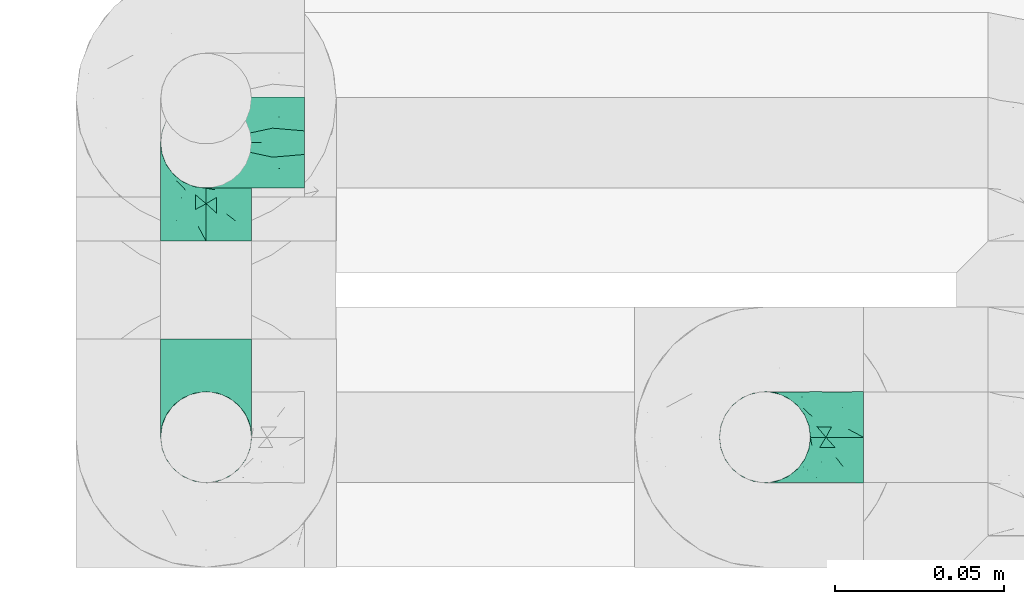
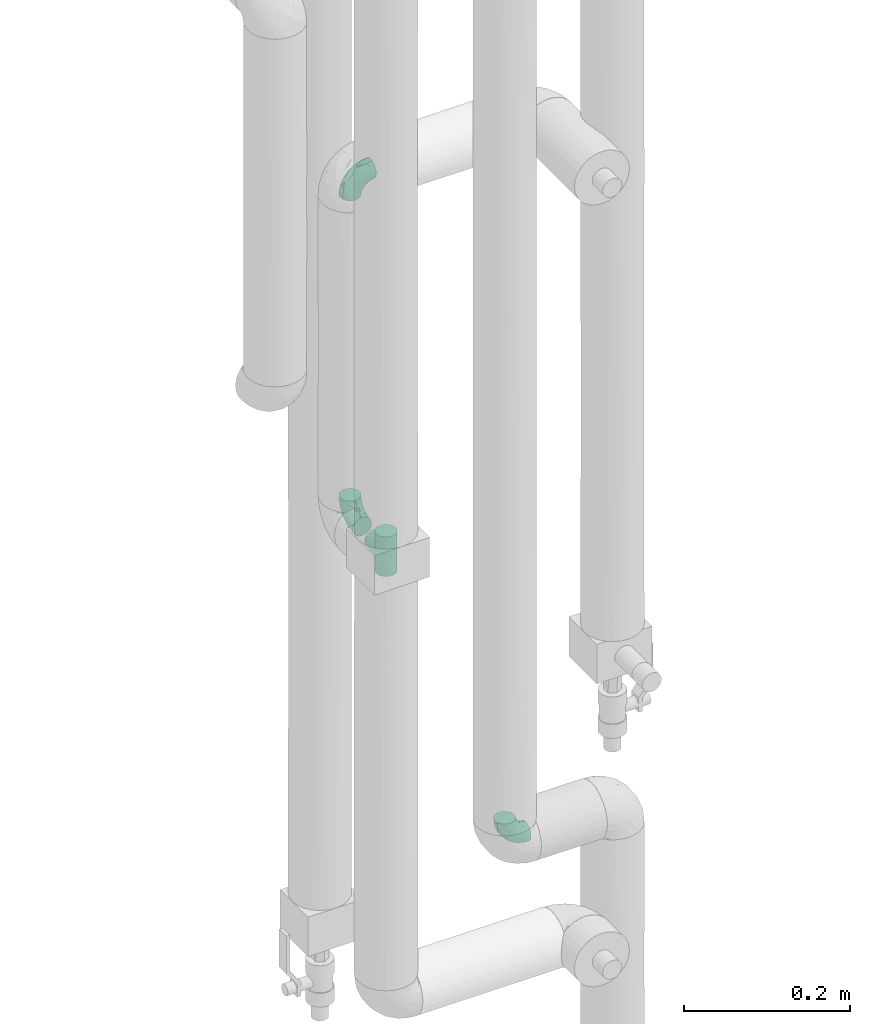
# One storey, part 758 of 827: 4 flow fittings.
"""IFC2X3 building model written with IfcOpenShell, lengths in millimetres."""

from ifc_helpers import new_model, entity, si_unit, converted_unit, derived_unit, direction, frame, origin, place, context, subcontext, project, spatial, faceted_brep, source, transform, mapped, material, type_object, type_shapes, element, save


model = new_model("IFC2X3")

# Units and contexts
model_context = context("Model", 3, precision=0.01, world=origin(), true_north=direction((6.12303176911189e-17, 1.0)))
body_context = subcontext(model_context, "Body", "Model", "MODEL_VIEW")
ifc_project = project(units=[si_unit("LENGTHUNIT", "METRE", prefix="MILLI"), si_unit("AREAUNIT", "SQUARE_METRE"), si_unit("VOLUMEUNIT", "CUBIC_METRE"), converted_unit("PLANEANGLEUNIT", "DEGREE", entity("IfcRatioMeasure", 0.0174532925199433), si_unit("PLANEANGLEUNIT", "RADIAN"), dimensions=[0, 0, 0, 0, 0, 0, 0]), si_unit("MASSUNIT", "GRAM", prefix="KILO"), derived_unit("MASSDENSITYUNIT", [(si_unit("MASSUNIT", "GRAM", prefix="KILO"), 1), (si_unit("LENGTHUNIT", "METRE"), -3)]), derived_unit("MOMENTOFINERTIAUNIT", [(si_unit("LENGTHUNIT", "METRE"), 4)]), si_unit("TIMEUNIT", "SECOND"), si_unit("FREQUENCYUNIT", "HERTZ"), si_unit("THERMODYNAMICTEMPERATUREUNIT", "DEGREE_CELSIUS"), derived_unit("THERMALTRANSMITTANCEUNIT", [(si_unit("MASSUNIT", "GRAM", prefix="KILO"), 1), (si_unit("THERMODYNAMICTEMPERATUREUNIT", "KELVIN"), -1), (si_unit("TIMEUNIT", "SECOND"), -3)]), derived_unit("VOLUMETRICFLOWRATEUNIT", [(si_unit("LENGTHUNIT", "METRE"), 3), (si_unit("TIMEUNIT", "SECOND"), -1)]), derived_unit("MASSFLOWRATEUNIT", [(si_unit("MASSUNIT", "GRAM", prefix="KILO"), 1), (si_unit("TIMEUNIT", "SECOND"), -1)]), derived_unit("ROTATIONALFREQUENCYUNIT", [(si_unit("TIMEUNIT", "SECOND"), -1)]), si_unit("ELECTRICCURRENTUNIT", "AMPERE"), si_unit("ELECTRICVOLTAGEUNIT", "VOLT"), si_unit("POWERUNIT", "WATT"), si_unit("FORCEUNIT", "NEWTON", prefix="KILO"), si_unit("ILLUMINANCEUNIT", "LUX"), si_unit("LUMINOUSFLUXUNIT", "LUMEN"), si_unit("LUMINOUSINTENSITYUNIT", "CANDELA"), derived_unit("USERDEFINED", [(si_unit("MASSUNIT", "GRAM", prefix="KILO"), -1), (si_unit("LENGTHUNIT", "METRE"), -2), (si_unit("TIMEUNIT", "SECOND"), 3), (si_unit("LUMINOUSFLUXUNIT", "LUMEN"), 1)]), derived_unit("LINEARVELOCITYUNIT", [(si_unit("LENGTHUNIT", "METRE"), 1), (si_unit("TIMEUNIT", "SECOND"), -1)]), si_unit("PRESSUREUNIT", "PASCAL"), derived_unit("USERDEFINED", [(si_unit("LENGTHUNIT", "METRE"), -2), (si_unit("MASSUNIT", "GRAM", prefix="KILO"), 1), (si_unit("TIMEUNIT", "SECOND"), -2)]), derived_unit("LINEARFORCEUNIT", [(si_unit("MASSUNIT", "GRAM", prefix="KILO"), 1), (si_unit("LENGTHUNIT", "METRE"), 1), (si_unit("TIMEUNIT", "SECOND"), -2), (si_unit("LENGTHUNIT", "METRE"), -1)]), derived_unit("PLANARFORCEUNIT", [(si_unit("MASSUNIT", "GRAM", prefix="KILO"), 1), (si_unit("LENGTHUNIT", "METRE"), 1), (si_unit("TIMEUNIT", "SECOND"), -2), (si_unit("LENGTHUNIT", "METRE"), -2)])], contexts=[model_context])

# Site, building, storey
site_placement = place(None, origin())
site = spatial("IfcSite", under=ifc_project, at=site_placement, CompositionType="ELEMENT")
building_placement = place(site_placement, origin())
building = spatial("IfcBuilding", under=site, at=building_placement, CompositionType="ELEMENT")
storey_placement = place(building_placement, frame((0.0, 0.0, 28200.0)))
storey = spatial("IfcBuildingStorey", under=building, at=storey_placement, Name="08", CompositionType="ELEMENT", Elevation=28200.0)

# Flow fittings
ifc_material = material()
pipe_fitting_type_1 = type_object("IfcPipeFittingType", Name="ADSK_1", PredefinedType="NOTDEFINED", material=ifc_material)
shared_shape_1 = source(origin(), body_context, "Body", "Brep", [
    faceted_brep([(-29.1, 0.0, -13.45), (-29.1, -3.48, -12.99), (-29.1, -6.73, -11.65), (-29.1, -9.51, -9.51), (-29.1, -11.65, -6.73), (-29.1, -12.99, -3.48), (-29.1, -13.45, 0.0), (-29.1, -12.99, 3.48), (-29.1, -11.65, 6.72), (-29.1, -9.51, 9.51), (-29.1, -6.73, 11.65), (-29.1, -3.48, 12.99), (-29.1, 0.0, 13.45), (-29.1, 3.48, 12.99), (-29.1, 6.72, 11.65), (-29.1, 9.51, 9.51), (-29.1, 11.65, 6.72), (-29.1, 12.99, 3.48), (-29.1, 13.45, 0.0), (-29.1, 12.99, -3.48), (-29.1, 11.65, -6.73), (-29.1, 9.51, -9.51), (-29.1, 6.72, -11.65), (-29.1, 3.48, -12.99), (-3.48, 29.1, -12.99), (-6.72, 29.1, -11.65), (-9.51, 29.1, -9.51), (-11.65, 29.1, -6.73), (-12.99, 29.1, -3.48), (-13.45, 29.1, 0.0), (-12.99, 29.1, 3.48), (-11.65, 29.1, 6.72), (-9.51, 29.1, 9.51), (-6.72, 29.1, 11.65), (-3.48, 29.1, 12.99), (0.0, 29.1, 13.45), (3.48, 29.1, 12.99), (6.73, 29.1, 11.65), (9.51, 29.1, 9.51), (11.65, 29.1, 6.72), (12.99, 29.1, 3.48), (13.45, 29.1, 0.0), (12.99, 29.1, -3.48), (11.65, 29.1, -6.73), (9.51, 29.1, -9.51), (6.73, 29.1, -11.65), (3.48, 29.1, -12.99), (0.0, 29.1, -13.45), (-19.62, -11.66, 4.28), (-21.41, -10.36, 7.6), (-16.26, -10.01, 0.0), (-12.48, -9.76, 2.75), (-10.66, 15.6, 11.91), (-15.27, 9.55, 12.42), (-10.71, 10.71, 13.09), (-0.04, 0.04, 0.0), (0.49, -0.45, 4.38), (-3.67, -4.15, 4.26), (-22.68, -11.73, 0.0), (-21.45, -4.97, 12.13), (-11.59, -2.84, 11.28), (-14.77, 0.17, 13.07), (-19.08, -7.58, 10.06), (-22.36, -1.69, 13.23), (-20.49, 2.21, 13.42), (-7.82, -7.75, 0.0), (-5.53, -2.55, 8.58), (-1.33, -0.87, 6.53), (-1.15, 1.15, 8.49), (-22.46, 5.38, 12.69), (-14.04, 21.05, 6.04), (-3.19, 3.19, 11.14), (-5.08, 25.05, 12.59), (-1.97, 21.79, 13.41), (-22.68, 11.31, 8.78), (-18.16, 12.64, 9.68), (-20.46, 14.33, 6.11), (-4.13, 10.11, 13.26), (-7.66, 3.08, 12.63), (-2.02, 8.24, 12.45), (-24.91, 8.22, 10.95), (-5.08, 14.28, 13.42), (-8.96, 6.48, 13.4), (-19.7, 16.14, 3.1), (-18.03, 18.03, 0.0), (-23.05, 15.96, 0.0), (-25.26, 12.69, 5.56), (4.97, 21.45, 12.13), (7.58, 19.08, 10.06), (1.69, 22.36, 13.23), (10.36, 21.41, 7.6), (8.11, 12.69, 6.86), (11.66, 19.62, 4.28), (-6.03, 19.65, 12.79), (9.76, 12.48, 2.75), (10.01, 16.26, 0.0), (-14.58, 16.06, 9.44), (-11.19, 23.14, 8.74), (-16.29, 16.8, 7.24), (-11.99, -5.68, 9.36), (-15.42, 20.78, 3.08), (5.79, 12.02, 9.27), (2.84, 11.59, 11.28), (2.55, 5.53, 8.58), (-15.74, 23.57, 0.0), (-15.96, 23.05, 0.0), (-24.62, 13.88, 2.39), (-8.61, 22.49, 11.12), (-14.98, 12.8, 11.14), (11.73, 22.68, 0.0), (-12.69, -8.11, 6.86), (7.75, 7.82, 0.0), (-15.98, 6.12, 13.19), (-14.48, 3.64, 13.45), (-19.6, 9.46, 11.31), (-8.3, 15.02, 12.85), (-0.17, 14.77, 13.07), (-6.9, -5.2, 6.52), (7.5, 8.93, 4.46), (5.22, 6.95, 6.56), (-8.85, -7.47, 4.42), (3.86, 3.93, 0.0), (4.18, 3.75, 4.31), (-23.57, 15.74, 0.0), (-3.93, -3.86, 0.0), (-21.79, 1.97, -13.41), (-11.31, 22.68, -8.78), (-14.33, 20.46, -6.11), (-12.69, 25.26, -5.56), (4.97, 21.45, -12.13), (2.84, 11.59, -11.28), (-0.17, 14.77, -13.07), (-25.05, 5.08, -12.59), (-16.8, 16.29, -7.24), (-20.78, 15.42, -3.08), (-16.14, 19.7, -3.1), (-12.02, -5.79, -9.27), (-11.59, -2.84, -11.28), (-5.53, -2.55, -8.58), (-23.14, 11.19, -8.74), (-22.49, 8.61, -11.12), (-1.33, -0.87, -6.53), (-3.67, -4.15, -4.26), (-6.9, -5.2, -6.52), (-19.65, 6.03, -12.79), (-15.6, 10.66, -11.91), (-14.28, 5.08, -13.42), (-10.71, 10.71, -13.09), (-6.48, 8.96, -13.4), (-19.62, -11.66, -4.28), (-21.41, -10.36, -7.6), (-12.48, -9.76, -2.75), (11.66, 19.62, -4.28), (-12.69, -8.11, -6.86), (-22.36, -1.69, -13.23), (-16.06, 14.58, -9.44), (5.68, 11.99, -9.36), (7.58, 19.08, -10.06), (-19.08, -7.58, -10.06), (-21.45, -4.97, -12.13), (-9.55, 15.27, -12.42), (-12.8, 14.98, -11.14), (-8.22, 24.91, -10.95), (10.36, 21.41, -7.6), (-5.38, 22.46, -12.69), (1.69, 22.36, -13.23), (-2.21, 20.49, -13.42), (-12.64, 18.16, -9.68), (-21.05, 14.04, -6.04), (9.76, 12.48, -2.75), (-10.11, 4.13, -13.26), (-3.08, 7.66, -12.63), (-8.24, 2.02, -12.45), (-13.88, 24.62, -2.39), (8.11, 12.69, -6.86), (-6.12, 15.98, -13.19), (-3.64, 14.48, -13.45), (-9.46, 19.6, -11.31), (-15.02, 8.3, -12.85), (-14.77, 0.17, -13.07), (-3.19, 3.19, -11.14), (5.22, 6.95, -6.56), (2.55, 5.53, -8.58), (0.49, -0.45, -4.38), (4.18, 3.75, -4.31), (-8.85, -7.47, -4.42), (-1.15, 1.15, -8.49), (7.5, 8.93, -4.46)], [[[0, 1, 2, 3, 4, 5, 6, 7, 8, 9, 10, 11, 12, 13, 14, 15, 16, 17, 18, 19, 20, 21, 22, 23]], [[24, 25, 26, 27, 28, 29, 30, 31, 32, 33, 34, 35, 36, 37, 38, 39, 40, 41, 42, 43, 44, 45, 46, 47]], [[48, 49, 8]], [[48, 50, 51]], [[52, 53, 54]], [[55, 56, 57]], [[49, 9, 8]], [[58, 48, 7]], [[59, 60, 61]], [[62, 10, 9]], [[62, 59, 10]], [[12, 63, 64]], [[51, 50, 65]], [[66, 67, 68]], [[12, 11, 63]], [[69, 14, 13]], [[31, 30, 70]], [[66, 71, 60]], [[34, 72, 73]], [[74, 75, 76]], [[77, 78, 79]], [[14, 80, 15]], [[16, 15, 74]], [[81, 54, 82]], [[83, 84, 85]], [[74, 76, 86]], [[37, 87, 88]], [[88, 38, 37]], [[36, 35, 89]], [[90, 91, 92]], [[93, 81, 73]], [[35, 34, 73]], [[10, 59, 11]], [[92, 94, 95]], [[96, 97, 98]], [[90, 92, 39]], [[99, 60, 62]], [[40, 39, 92]], [[87, 37, 36]], [[100, 84, 83]], [[50, 48, 58]], [[100, 83, 98]], [[101, 102, 103]], [[104, 105, 84, 100, 29]], [[48, 8, 7]], [[86, 17, 16]], [[106, 18, 17]], [[32, 97, 107]], [[53, 52, 108]], [[52, 93, 107]], [[97, 96, 107]], [[72, 107, 93]], [[72, 34, 33]], [[92, 109, 40]], [[33, 32, 107]], [[69, 13, 64]], [[88, 87, 102]], [[12, 64, 13]], [[49, 110, 62]], [[39, 38, 90]], [[95, 94, 111]], [[112, 113, 82]], [[53, 69, 112]], [[80, 74, 15]], [[114, 108, 75]], [[32, 31, 97]], [[115, 52, 54]], [[93, 115, 81]], [[89, 73, 116]], [[106, 76, 83]], [[106, 83, 85]], [[83, 76, 98]], [[100, 30, 29]], [[60, 59, 62]], [[63, 59, 61]], [[110, 117, 99]], [[60, 71, 78]], [[89, 87, 36]], [[116, 79, 102]], [[116, 102, 87]], [[102, 71, 103]], [[110, 49, 48]], [[62, 9, 49]], [[38, 88, 90]], [[91, 90, 88]], [[112, 69, 64]], [[80, 69, 114]], [[111, 94, 118]], [[119, 101, 103]], [[117, 66, 99]], [[117, 120, 57]], [[119, 91, 101]], [[66, 68, 71]], [[66, 117, 67]], [[121, 111, 122, 55]], [[56, 55, 122]], [[31, 70, 97]], [[97, 70, 98]], [[107, 96, 52]], [[53, 108, 114]], [[112, 82, 54]], [[116, 73, 81]], [[78, 82, 61]], [[81, 82, 77]], [[73, 89, 35]], [[87, 89, 116]], [[59, 63, 11]], [[64, 63, 61]], [[112, 64, 113]], [[53, 112, 54]], [[7, 6, 58]], [[109, 92, 95]], [[109, 41, 40]], [[69, 53, 114]], [[52, 96, 108]], [[75, 108, 96]], [[75, 96, 98]], [[114, 75, 74]], [[64, 61, 113]], [[61, 82, 113]], [[91, 88, 101]], [[110, 48, 51]], [[92, 91, 94]], [[91, 119, 118]], [[106, 85, 123, 18]], [[106, 17, 86]], [[60, 78, 61]], [[79, 78, 71]], [[102, 79, 71]], [[77, 79, 116]], [[81, 77, 116]], [[78, 77, 82]], [[69, 80, 14]], [[74, 80, 114]], [[74, 86, 16]], [[106, 86, 76]], [[107, 72, 33]], [[73, 72, 93]], [[98, 70, 100]], [[75, 98, 76]], [[30, 100, 70]], [[110, 99, 62]], [[66, 60, 99]], [[120, 110, 51]], [[67, 117, 57]], [[57, 56, 67]], [[67, 122, 119]], [[110, 120, 117]], [[65, 120, 51]], [[57, 65, 124, 55]], [[122, 67, 56]], [[67, 103, 68]], [[71, 68, 103]], [[65, 57, 120]], [[102, 101, 88]], [[67, 119, 103]], [[118, 119, 122]], [[118, 122, 111]], [[91, 118, 94]], [[81, 115, 54]], [[93, 52, 115]], [[23, 125, 0]], [[126, 127, 128]], [[129, 130, 131]], [[23, 22, 132]], [[133, 134, 135]], [[136, 137, 138]], [[21, 139, 140]], [[141, 142, 143]], [[144, 140, 145]], [[143, 136, 138]], [[146, 147, 148]], [[144, 132, 140]], [[5, 4, 149]], [[4, 3, 150]], [[45, 129, 46]], [[151, 50, 149]], [[152, 43, 42]], [[42, 41, 109]], [[150, 149, 4]], [[153, 149, 150]], [[154, 1, 0]], [[139, 155, 140]], [[156, 130, 157]], [[149, 58, 5]], [[18, 123, 85, 84, 134]], [[158, 159, 137]], [[84, 105, 135]], [[160, 145, 161]], [[143, 153, 136]], [[27, 26, 126]], [[25, 162, 26]], [[152, 163, 43]], [[25, 24, 164]], [[47, 165, 166]], [[158, 3, 2]], [[167, 127, 126]], [[20, 19, 168]], [[47, 46, 165]], [[44, 157, 45]], [[23, 132, 125]], [[44, 43, 163]], [[158, 2, 159]], [[47, 166, 24]], [[129, 45, 157]], [[164, 24, 166]], [[134, 84, 135]], [[95, 169, 152]], [[22, 21, 140]], [[144, 146, 125]], [[109, 152, 42]], [[95, 152, 109]], [[170, 171, 172]], [[155, 139, 133]], [[28, 27, 128]], [[159, 2, 1]], [[173, 29, 28]], [[50, 151, 65]], [[169, 95, 111]], [[163, 174, 157]], [[175, 176, 148]], [[160, 164, 175]], [[162, 126, 26]], [[177, 161, 167]], [[21, 20, 139]], [[144, 145, 178]], [[144, 178, 146]], [[154, 125, 179]], [[173, 127, 135]], [[173, 135, 105]], [[135, 127, 133]], [[134, 19, 18]], [[154, 159, 1]], [[179, 172, 137]], [[179, 137, 159]], [[137, 180, 138]], [[130, 129, 157]], [[165, 129, 131]], [[174, 181, 156]], [[130, 180, 171]], [[3, 158, 150]], [[153, 150, 158]], [[174, 163, 152]], [[157, 44, 163]], [[175, 164, 166]], [[162, 164, 177]], [[130, 182, 180]], [[181, 141, 182]], [[55, 183, 184]], [[65, 151, 185]], [[183, 55, 142]], [[156, 181, 182]], [[180, 182, 186]], [[181, 187, 184]], [[65, 142, 55, 124]], [[20, 168, 139]], [[139, 168, 133]], [[140, 155, 145]], [[160, 161, 177]], [[175, 148, 147]], [[179, 125, 146]], [[171, 148, 131]], [[146, 148, 170]], [[125, 154, 0]], [[159, 154, 179]], [[129, 165, 46]], [[166, 165, 131]], [[175, 166, 176]], [[160, 175, 147]], [[58, 149, 50]], [[58, 6, 5]], [[145, 160, 147]], [[164, 160, 177]], [[145, 155, 161]], [[167, 161, 155]], [[167, 155, 133]], [[177, 167, 126]], [[166, 131, 176]], [[131, 148, 176]], [[149, 153, 151]], [[153, 143, 185]], [[145, 147, 178]], [[174, 152, 169]], [[173, 105, 104, 29]], [[173, 28, 128]], [[130, 171, 131]], [[172, 171, 180]], [[137, 172, 180]], [[170, 172, 179]], [[146, 170, 179]], [[171, 170, 148]], [[164, 162, 25]], [[126, 162, 177]], [[126, 128, 27]], [[173, 128, 127]], [[140, 132, 22]], [[125, 132, 144]], [[133, 168, 134]], [[167, 133, 127]], [[19, 134, 168]], [[153, 158, 136]], [[137, 136, 158]], [[141, 143, 138]], [[185, 143, 142]], [[186, 141, 138]], [[183, 142, 141]], [[185, 142, 65]], [[153, 185, 151]], [[180, 186, 138]], [[182, 141, 186]], [[141, 184, 183]], [[184, 111, 121, 55]], [[174, 156, 157]], [[182, 130, 156]], [[187, 174, 169]], [[141, 181, 184]], [[174, 187, 181]], [[111, 187, 169]], [[111, 184, 187]], [[146, 178, 147]]]),
])
type_shapes(pipe_fitting_type_1, [shared_shape_1])
flow_fitting_1_placement = place(storey_placement, frame((34690.42, 18334.91, 1230.0), z_axis=(0.0, 1.0, 0.0), x_axis=(-1.0, 0.0, 0.0)))
element("IfcFlowFitting", 1, at=flow_fitting_1_placement, inside=storey, type_object=pipe_fitting_type_1, material=ifc_material, Name="ADSK_1", ObjectType="ADSK_1", context=body_context, shape_type="MappedRepresentation", body=[
    mapped(shared_shape_1, transform((0.0, 0.0, 0.0), scale=1.0)),
])
pipe_fitting_type_2 = type_object("IfcPipeFittingType", Name="ADSK_1", PredefinedType="NOTDEFINED", material=ifc_material)
shared_shape_2 = source(origin(), body_context, "Body", "Brep", [
    faceted_brep([(-29.1, -3.48, -12.99), (-29.1, -6.72, -11.65), (-29.1, -9.51, -9.51), (-29.1, -11.65, -6.73), (-29.1, -12.99, -3.48), (-29.1, -13.45, 0.0), (-29.1, -12.99, 3.48), (-29.1, -11.65, 6.72), (-29.1, -9.51, 9.51), (-29.1, -6.72, 11.65), (-29.1, -3.48, 12.99), (-29.1, 0.0, 13.45), (-29.1, 3.48, 12.99), (-29.1, 6.73, 11.65), (-29.1, 9.51, 9.51), (-29.1, 11.65, 6.72), (-29.1, 12.99, 3.48), (-29.1, 13.45, 0.0), (-29.1, 12.99, -3.48), (-29.1, 11.65, -6.73), (-29.1, 9.51, -9.51), (-29.1, 6.73, -11.65), (-29.1, 3.48, -12.99), (-29.1, 0.0, -13.45), (0.0, -29.1, -13.45), (3.48, -29.1, -12.99), (6.73, -29.1, -11.65), (9.51, -29.1, -9.51), (11.65, -29.1, -6.73), (12.99, -29.1, -3.48), (13.45, -29.1, 0.0), (12.99, -29.1, 3.48), (11.65, -29.1, 6.72), (9.51, -29.1, 9.51), (6.73, -29.1, 11.65), (3.48, -29.1, 12.99), (0.0, -29.1, 13.45), (-3.48, -29.1, 12.99), (-6.72, -29.1, 11.65), (-9.51, -29.1, 9.51), (-11.65, -29.1, 6.72), (-12.99, -29.1, 3.48), (-13.45, -29.1, 0.0), (-12.99, -29.1, -3.48), (-11.65, -29.1, -6.73), (-9.51, -29.1, -9.51), (-6.72, -29.1, -11.65), (-3.48, -29.1, -12.99), (-21.41, 10.36, 7.6), (-19.62, 11.66, 4.28), (-12.48, 9.76, 2.75), (-16.26, 10.01, 0.0), (-10.71, -10.71, 13.09), (-15.27, -9.55, 12.42), (-10.66, -15.6, 11.91), (-3.67, 4.15, 4.26), (0.49, 0.45, 4.38), (-0.04, -0.04, 0.0), (-22.68, 11.73, 0.0), (-14.77, -0.17, 13.07), (-11.59, 2.84, 11.28), (-21.45, 4.97, 12.13), (-19.08, 7.58, 10.06), (-20.49, -2.21, 13.42), (-22.36, 1.69, 13.23), (-7.82, 7.75, 0.0), (-1.15, -1.15, 8.49), (-1.33, 0.87, 6.53), (-5.53, 2.55, 8.58), (-22.46, -5.38, 12.69), (-14.04, -21.05, 6.04), (-3.19, -3.19, 11.14), (-1.97, -21.79, 13.41), (-5.08, -25.05, 12.59), (-20.46, -14.33, 6.11), (-18.16, -12.64, 9.68), (-22.68, -11.31, 8.78), (-2.02, -8.24, 12.45), (-7.66, -3.08, 12.63), (-4.13, -10.11, 13.26), (-24.91, -8.22, 10.95), (-8.96, -6.48, 13.4), (-5.08, -14.28, 13.42), (-23.05, -15.96, 0.0), (-18.03, -18.03, 0.0), (-19.7, -16.14, 3.1), (-25.26, -12.69, 5.56), (7.58, -19.08, 10.06), (4.97, -21.45, 12.13), (1.69, -22.36, 13.23), (11.66, -19.62, 4.28), (8.11, -12.69, 6.86), (10.36, -21.41, 7.6), (-6.03, -19.65, 12.79), (10.01, -16.26, 0.0), (9.76, -12.48, 2.75), (-16.29, -16.8, 7.24), (-11.19, -23.14, 8.74), (-14.58, -16.06, 9.44), (-11.99, 5.68, 9.36), (-15.42, -20.78, 3.08), (2.55, -5.53, 8.58), (2.84, -11.59, 11.28), (5.79, -12.02, 9.27), (-15.96, -23.05, 0.0), (-15.74, -23.57, 0.0), (-24.62, -13.88, 2.39), (-8.61, -22.49, 11.12), (-14.98, -12.8, 11.14), (11.73, -22.68, 0.0), (-12.69, 8.11, 6.86), (7.75, -7.82, 0.0), (-14.48, -3.64, 13.45), (-15.98, -6.12, 13.19), (-19.6, -9.46, 11.31), (-8.3, -15.02, 12.85), (-0.17, -14.77, 13.07), (-6.9, 5.2, 6.52), (7.5, -8.93, 4.46), (5.22, -6.95, 6.56), (-8.85, 7.47, 4.42), (4.18, -3.75, 4.31), (3.86, -3.93, 0.0), (-23.57, -15.74, 0.0), (-3.93, 3.86, 0.0), (-21.79, -1.97, -13.41), (-12.69, -25.26, -5.56), (-14.33, -20.46, -6.11), (-11.31, -22.68, -8.78), (-0.17, -14.77, -13.07), (2.84, -11.59, -11.28), (4.97, -21.45, -12.13), (-25.05, -5.08, -12.59), (-16.14, -19.7, -3.1), (-20.78, -15.42, -3.08), (-16.8, -16.29, -7.24), (-5.53, 2.55, -8.58), (-11.59, 2.84, -11.28), (-12.02, 5.79, -9.27), (-22.49, -8.61, -11.12), (-23.14, -11.19, -8.74), (-6.9, 5.2, -6.52), (-3.67, 4.15, -4.26), (-1.33, 0.87, -6.53), (-15.6, -10.66, -11.91), (-19.65, -6.03, -12.79), (-6.48, -8.96, -13.4), (-10.71, -10.71, -13.09), (-14.28, -5.08, -13.42), (-19.62, 11.66, -4.28), (-21.41, 10.36, -7.6), (-12.48, 9.76, -2.75), (11.66, -19.62, -4.28), (-12.69, 8.11, -6.86), (-22.36, 1.69, -13.23), (-16.06, -14.58, -9.44), (7.58, -19.08, -10.06), (5.68, -11.99, -9.36), (-21.45, 4.97, -12.13), (-19.08, 7.58, -10.06), (-12.8, -14.98, -11.14), (-9.55, -15.27, -12.42), (-8.22, -24.91, -10.95), (10.36, -21.41, -7.6), (-5.38, -22.46, -12.69), (-2.21, -20.49, -13.42), (1.69, -22.36, -13.23), (-12.64, -18.16, -9.68), (-21.05, -14.04, -6.04), (9.76, -12.48, -2.75), (-8.24, -2.02, -12.45), (-3.08, -7.66, -12.63), (-10.11, -4.13, -13.26), (-13.88, -24.62, -2.39), (8.11, -12.69, -6.86), (-3.64, -14.48, -13.45), (-6.12, -15.98, -13.19), (-9.46, -19.6, -11.31), (-15.02, -8.3, -12.85), (-14.77, -0.17, -13.07), (-3.19, -3.19, -11.14), (5.22, -6.95, -6.56), (2.55, -5.53, -8.58), (4.18, -3.75, -4.31), (0.49, 0.45, -4.38), (-8.85, 7.47, -4.42), (-1.15, -1.15, -8.49), (7.5, -8.93, -4.46)], [[[0, 1, 2, 3, 4, 5, 6, 7, 8, 9, 10, 11, 12, 13, 14, 15, 16, 17, 18, 19, 20, 21, 22, 23]], [[24, 25, 26, 27, 28, 29, 30, 31, 32, 33, 34, 35, 36, 37, 38, 39, 40, 41, 42, 43, 44, 45, 46, 47]], [[15, 48, 49]], [[50, 51, 49]], [[52, 53, 54]], [[55, 56, 57]], [[15, 14, 48]], [[16, 49, 58]], [[59, 60, 61]], [[14, 13, 62]], [[13, 61, 62]], [[63, 64, 11]], [[65, 51, 50]], [[66, 67, 68]], [[64, 12, 11]], [[10, 9, 69]], [[70, 41, 40]], [[60, 71, 68]], [[72, 73, 37]], [[74, 75, 76]], [[77, 78, 79]], [[8, 80, 9]], [[76, 8, 7]], [[81, 52, 82]], [[83, 84, 85]], [[86, 74, 76]], [[87, 88, 34]], [[34, 33, 87]], [[89, 36, 35]], [[90, 91, 92]], [[72, 82, 93]], [[72, 37, 36]], [[12, 61, 13]], [[94, 95, 90]], [[96, 97, 98]], [[32, 90, 92]], [[62, 60, 99]], [[90, 32, 31]], [[35, 34, 88]], [[85, 84, 100]], [[58, 49, 51]], [[96, 85, 100]], [[101, 102, 103]], [[42, 100, 84, 104, 105]], [[16, 15, 49]], [[7, 6, 86]], [[6, 5, 106]], [[107, 97, 39]], [[108, 54, 53]], [[107, 93, 54]], [[107, 98, 97]], [[93, 107, 73]], [[38, 37, 73]], [[31, 109, 90]], [[107, 39, 38]], [[63, 10, 69]], [[102, 88, 87]], [[10, 63, 11]], [[62, 110, 48]], [[92, 33, 32]], [[111, 95, 94]], [[81, 112, 113]], [[113, 69, 53]], [[8, 76, 80]], [[75, 108, 114]], [[97, 40, 39]], [[52, 54, 115]], [[82, 115, 93]], [[116, 72, 89]], [[85, 74, 106]], [[83, 85, 106]], [[96, 74, 85]], [[42, 41, 100]], [[62, 61, 60]], [[59, 61, 64]], [[99, 117, 110]], [[78, 71, 60]], [[35, 88, 89]], [[102, 77, 116]], [[88, 102, 116]], [[101, 71, 102]], [[49, 48, 110]], [[48, 14, 62]], [[92, 87, 33]], [[87, 92, 91]], [[63, 69, 113]], [[114, 69, 80]], [[118, 95, 111]], [[101, 103, 119]], [[99, 68, 117]], [[55, 120, 117]], [[103, 91, 119]], [[71, 66, 68]], [[67, 117, 68]], [[121, 111, 122, 57]], [[121, 57, 56]], [[97, 70, 40]], [[96, 70, 97]], [[54, 98, 107]], [[114, 108, 53]], [[52, 81, 113]], [[82, 72, 116]], [[59, 81, 78]], [[79, 81, 82]], [[36, 89, 72]], [[116, 89, 88]], [[12, 64, 61]], [[59, 64, 63]], [[112, 63, 113]], [[52, 113, 53]], [[58, 17, 16]], [[94, 90, 109]], [[31, 30, 109]], [[114, 53, 69]], [[108, 98, 54]], [[98, 108, 75]], [[96, 98, 75]], [[76, 75, 114]], [[112, 59, 63]], [[112, 81, 59]], [[103, 87, 91]], [[50, 49, 110]], [[95, 91, 90]], [[118, 119, 91]], [[106, 5, 123, 83]], [[86, 6, 106]], [[59, 78, 60]], [[71, 78, 77]], [[71, 77, 102]], [[116, 77, 79]], [[116, 79, 82]], [[81, 79, 78]], [[9, 80, 69]], [[114, 80, 76]], [[7, 86, 76]], [[74, 86, 106]], [[38, 73, 107]], [[93, 73, 72]], [[100, 70, 96]], [[74, 96, 75]], [[70, 100, 41]], [[62, 99, 110]], [[99, 60, 68]], [[50, 110, 120]], [[55, 117, 67]], [[67, 56, 55]], [[119, 121, 67]], [[117, 120, 110]], [[50, 120, 65]], [[124, 65, 55, 57]], [[56, 67, 121]], [[66, 101, 67]], [[101, 66, 71]], [[120, 55, 65]], [[87, 103, 102]], [[101, 119, 67]], [[121, 119, 118]], [[111, 121, 118]], [[95, 118, 91]], [[52, 115, 82]], [[115, 54, 93]], [[23, 125, 0]], [[126, 127, 128]], [[129, 130, 131]], [[132, 1, 0]], [[133, 134, 135]], [[136, 137, 138]], [[139, 140, 2]], [[141, 142, 143]], [[144, 139, 145]], [[136, 138, 141]], [[146, 147, 148]], [[139, 132, 145]], [[149, 19, 18]], [[150, 20, 19]], [[25, 131, 26]], [[149, 51, 151]], [[29, 28, 152]], [[109, 30, 29]], [[19, 149, 150]], [[150, 149, 153]], [[23, 22, 154]], [[139, 155, 140]], [[156, 130, 157]], [[18, 58, 149]], [[134, 84, 83, 123, 5]], [[137, 158, 159]], [[133, 104, 84]], [[160, 144, 161]], [[138, 153, 141]], [[128, 45, 44]], [[45, 162, 46]], [[28, 163, 152]], [[164, 47, 46]], [[165, 166, 24]], [[21, 20, 159]], [[128, 127, 167]], [[168, 4, 3]], [[166, 25, 24]], [[26, 156, 27]], [[125, 132, 0]], [[163, 28, 27]], [[158, 21, 159]], [[47, 165, 24]], [[156, 26, 131]], [[165, 47, 164]], [[133, 84, 134]], [[152, 169, 94]], [[139, 2, 1]], [[125, 148, 145]], [[29, 152, 109]], [[109, 152, 94]], [[170, 171, 172]], [[135, 140, 155]], [[126, 44, 43]], [[22, 21, 158]], [[43, 42, 173]], [[65, 151, 51]], [[111, 94, 169]], [[156, 174, 163]], [[146, 175, 176]], [[176, 164, 161]], [[45, 128, 162]], [[167, 160, 177]], [[140, 3, 2]], [[178, 144, 145]], [[148, 178, 145]], [[179, 125, 154]], [[133, 127, 173]], [[104, 133, 173]], [[135, 127, 133]], [[5, 4, 134]], [[22, 158, 154]], [[137, 170, 179]], [[158, 137, 179]], [[136, 180, 137]], [[156, 131, 130]], [[129, 131, 166]], [[157, 181, 174]], [[171, 180, 130]], [[150, 159, 20]], [[159, 150, 153]], [[152, 163, 174]], [[163, 27, 156]], [[165, 164, 176]], [[177, 164, 162]], [[180, 182, 130]], [[182, 143, 181]], [[183, 184, 57]], [[185, 151, 65]], [[142, 57, 184]], [[182, 181, 157]], [[186, 182, 180]], [[183, 187, 181]], [[124, 57, 142, 65]], [[140, 168, 3]], [[135, 168, 140]], [[144, 155, 139]], [[177, 160, 161]], [[147, 146, 176]], [[148, 125, 179]], [[129, 146, 171]], [[172, 146, 148]], [[23, 154, 125]], [[179, 154, 158]], [[25, 166, 131]], [[129, 166, 165]], [[175, 165, 176]], [[147, 176, 161]], [[51, 149, 58]], [[18, 17, 58]], [[147, 161, 144]], [[177, 161, 164]], [[160, 155, 144]], [[155, 160, 167]], [[135, 155, 167]], [[128, 167, 177]], [[175, 129, 165]], [[175, 146, 129]], [[151, 153, 149]], [[185, 141, 153]], [[178, 147, 144]], [[169, 152, 174]], [[173, 42, 105, 104]], [[126, 43, 173]], [[129, 171, 130]], [[180, 171, 170]], [[180, 170, 137]], [[179, 170, 172]], [[179, 172, 148]], [[146, 172, 171]], [[46, 162, 164]], [[177, 162, 128]], [[44, 126, 128]], [[127, 126, 173]], [[1, 132, 139]], [[145, 132, 125]], [[134, 168, 135]], [[127, 135, 167]], [[168, 134, 4]], [[138, 159, 153]], [[159, 138, 137]], [[136, 141, 143]], [[142, 141, 185]], [[136, 143, 186]], [[143, 142, 184]], [[65, 142, 185]], [[151, 185, 153]], [[136, 186, 180]], [[186, 143, 182]], [[184, 183, 143]], [[122, 111, 183, 57]], [[156, 157, 174]], [[157, 130, 182]], [[169, 174, 187]], [[183, 181, 143]], [[181, 187, 174]], [[169, 187, 111]], [[187, 183, 111]], [[147, 178, 148]]]),
])
type_shapes(pipe_fitting_type_2, [shared_shape_2])
for number, where, z_axis, x_axis, name in (
    (2, (34525.39, 18421.91, 2210.0), (0.0, 1.0, 0.0), (-1.0, 0.0, 0.0), "ADSK_1"),
    (3, (34525.39, 18421.91, 1710.0), (-1.0, 0.0, 0.0), (0.0, 1.0, 0.0), "ADSK_1"),
):
    element("IfcFlowFitting", number, at=place(storey_placement, frame(where, z_axis=z_axis, x_axis=x_axis)), inside=storey, type_object=pipe_fitting_type_2, material=ifc_material, Name=name, ObjectType="ADSK_1", context=body_context, shape_type="MappedRepresentation", body=[
        mapped(shared_shape_2, transform((0.0, 0.0, 0.0), scale=1.0)),
    ])
pipe_fitting_type_3 = type_object("IfcPipeFittingType", Name="ADSK_1", PredefinedType="NOTDEFINED", material=ifc_material)
shared_shape_3 = source(origin(), body_context, "Body", "Brep", [
    faceted_brep([(-29.0, -11.65, -6.73), (-29.0, -12.99, -3.48), (-29.0, -13.45, 0.0), (-29.0, -12.99, 3.48), (-29.0, -11.65, 6.72), (-29.0, -9.51, 9.51), (-29.0, -6.72, 11.65), (-29.0, -3.48, 12.99), (-29.0, 0.0, 13.45), (-29.0, 3.48, 12.99), (-29.0, 6.73, 11.65), (-29.0, 9.51, 9.51), (-29.0, 11.65, 6.72), (-29.0, 12.99, 3.48), (-29.0, 13.45, 0.0), (-29.0, 12.99, -3.48), (-29.0, 11.65, -6.73), (-29.0, 9.51, -9.51), (-29.0, 6.73, -11.65), (-29.0, 3.48, -12.99), (-29.0, 0.0, -13.45), (-29.0, -3.48, -12.99), (-29.0, -6.72, -11.65), (-29.0, -9.51, -9.51), (29.0, -3.48, -12.99), (29.0, 0.0, -13.45), (29.0, 3.48, -12.99), (29.0, 6.73, -11.65), (29.0, 9.51, -9.51), (29.0, 11.65, -6.73), (29.0, 12.99, -3.48), (29.0, 13.45, 0.0), (29.0, 12.99, 3.48), (29.0, 11.65, 6.72), (29.0, 9.51, 9.51), (29.0, 6.73, 11.65), (29.0, 3.48, 12.99), (29.0, 0.0, 13.45), (29.0, -3.48, 12.99), (29.0, -6.72, 11.65), (29.0, -9.51, 9.51), (29.0, -11.65, 6.72), (29.0, -12.99, 3.48), (29.0, -13.45, 0.0), (29.0, -12.99, -3.48), (29.0, -11.65, -6.73), (29.0, -9.51, -9.51), (29.0, -6.72, -11.65), (12.96, 12.96, 3.59), (13.45, 13.45, 0.0), (-13.45, 13.45, 0.0), (11.64, 11.64, 6.74), (7.54, 7.54, 11.14), (9.76, 9.76, 9.25), (-12.96, 12.96, 3.59), (-11.64, 11.64, 6.74), (-7.54, 7.54, 11.14), (-9.76, 9.76, 9.25), (-5.12, 5.12, 12.44), (5.12, 5.12, 12.44), (0.0, 0.0, 13.45), (2.58, 2.58, 13.2), (-2.58, 2.58, 13.2), (2.58, 2.58, -13.2), (0.0, 0.0, -13.45), (-2.58, 2.58, -13.2), (-5.12, 5.12, -12.44), (5.12, 5.12, -12.44), (7.54, 7.54, -11.14), (9.76, 9.76, -9.25), (11.64, 11.64, -6.74), (12.96, 12.96, -3.59), (-7.54, 7.54, -11.14), (-9.76, 9.76, -9.25), (-12.96, 12.96, -3.59), (-11.64, 11.64, -6.74), (3.48, 29.0, -12.99), (0.0, 29.0, -13.45), (-3.48, 29.0, -12.99), (-6.72, 29.0, -11.65), (-9.51, 29.0, -9.51), (-11.65, 29.0, -6.73), (-12.99, 29.0, -3.48), (-13.45, 29.0, 0.0), (-12.99, 29.0, 3.48), (-11.65, 29.0, 6.72), (-9.51, 29.0, 9.51), (-6.72, 29.0, 11.65), (-3.48, 29.0, 12.99), (0.0, 29.0, 13.45), (3.48, 29.0, 12.99), (6.73, 29.0, 11.65), (9.51, 29.0, 9.51), (11.65, 29.0, 6.72), (12.99, 29.0, 3.48), (13.45, 29.0, 0.0), (12.99, 29.0, -3.48), (11.65, 29.0, -6.73), (9.51, 29.0, -9.51), (6.73, 29.0, -11.65)], [[[0, 1, 2, 3, 4, 5, 6, 7, 8, 9, 10, 11, 12, 13, 14, 15, 16, 17, 18, 19, 20, 21, 22, 23]], [[24, 25, 26, 27, 28, 29, 30, 31, 32, 33, 34, 35, 36, 37, 38, 39, 40, 41, 42, 43, 44, 45, 46, 47]], [[48, 33, 32]], [[49, 32, 31]], [[14, 13, 50]], [[48, 32, 49]], [[48, 51, 33]], [[52, 35, 34]], [[53, 33, 51]], [[34, 53, 52]], [[34, 33, 53]], [[13, 54, 50]], [[12, 54, 13]], [[12, 55, 54]], [[11, 56, 57]], [[57, 12, 11]], [[10, 56, 11]], [[55, 12, 57]], [[58, 56, 10]], [[59, 35, 52]], [[60, 37, 61]], [[8, 60, 62]], [[61, 36, 59]], [[35, 59, 36]], [[37, 36, 61]], [[38, 37, 60, 8, 7]], [[3, 42, 41, 4]], [[40, 39, 6, 5]], [[41, 40, 5, 4]], [[6, 39, 38, 7]], [[43, 42, 3, 2]], [[58, 9, 62]], [[8, 62, 9]], [[10, 9, 58]], [[45, 0, 23, 46]], [[43, 2, 1, 44]], [[0, 45, 44, 1]], [[47, 46, 23, 22]], [[63, 26, 25]], [[24, 21, 20, 64, 25]], [[63, 25, 64]], [[65, 64, 20]], [[21, 24, 47, 22]], [[19, 66, 65]], [[19, 65, 20]], [[19, 18, 66]], [[67, 26, 63]], [[68, 28, 27]], [[28, 68, 69]], [[69, 70, 29]], [[29, 28, 69]], [[67, 68, 27]], [[49, 31, 30]], [[14, 50, 15]], [[29, 71, 30]], [[49, 30, 71]], [[70, 71, 29]], [[66, 18, 72]], [[18, 17, 72]], [[73, 72, 17]], [[16, 73, 17]], [[15, 50, 74]], [[16, 74, 75]], [[16, 15, 74]], [[73, 16, 75]], [[26, 67, 27]], [[76, 77, 78, 79, 80, 81, 82, 83, 84, 85, 86, 87, 88, 89, 90, 91, 92, 93, 94, 95, 96, 97, 98, 99]], [[50, 84, 83]], [[84, 50, 54]], [[56, 87, 86]], [[57, 86, 85]], [[84, 54, 85]], [[88, 87, 58]], [[85, 54, 55]], [[85, 55, 57]], [[87, 56, 58]], [[62, 60, 89]], [[62, 88, 58]], [[56, 86, 57]], [[89, 88, 62]], [[90, 89, 61]], [[90, 59, 91]], [[48, 94, 93]], [[93, 92, 53]], [[92, 91, 52]], [[95, 94, 49]], [[90, 61, 59]], [[91, 59, 52]], [[94, 48, 49]], [[93, 53, 51]], [[93, 51, 48]], [[53, 92, 52]], [[60, 61, 89]], [[49, 96, 95]], [[96, 49, 71]], [[98, 97, 69]], [[99, 98, 68]], [[71, 97, 96]], [[76, 99, 67]], [[97, 71, 70]], [[97, 70, 69]], [[99, 68, 67]], [[63, 64, 77]], [[63, 76, 67]], [[68, 98, 69]], [[77, 76, 63]], [[78, 77, 65]], [[78, 66, 79]], [[74, 82, 81]], [[81, 80, 73]], [[80, 79, 72]], [[83, 82, 50]], [[78, 65, 66]], [[79, 66, 72]], [[82, 74, 50]], [[81, 73, 75]], [[81, 75, 74]], [[73, 80, 72]], [[64, 65, 77]]]),
])
type_shapes(pipe_fitting_type_3, [shared_shape_3])
flow_fitting_2_placement = place(storey_placement, frame((34525.39, 18334.91, 1710.0), z_axis=(-1.0, 0.0, 0.0), x_axis=(0.0, 0.0, 1.0)))
element("IfcFlowFitting", 4, at=flow_fitting_2_placement, inside=storey, type_object=pipe_fitting_type_3, material=ifc_material, Name="ADSK_1", ObjectType="ADSK_1", context=body_context, shape_type="MappedRepresentation", body=[
    mapped(shared_shape_3, transform((0.0, 0.0, 0.0), scale=1.0)),
])

save(model, "model.ifc")
